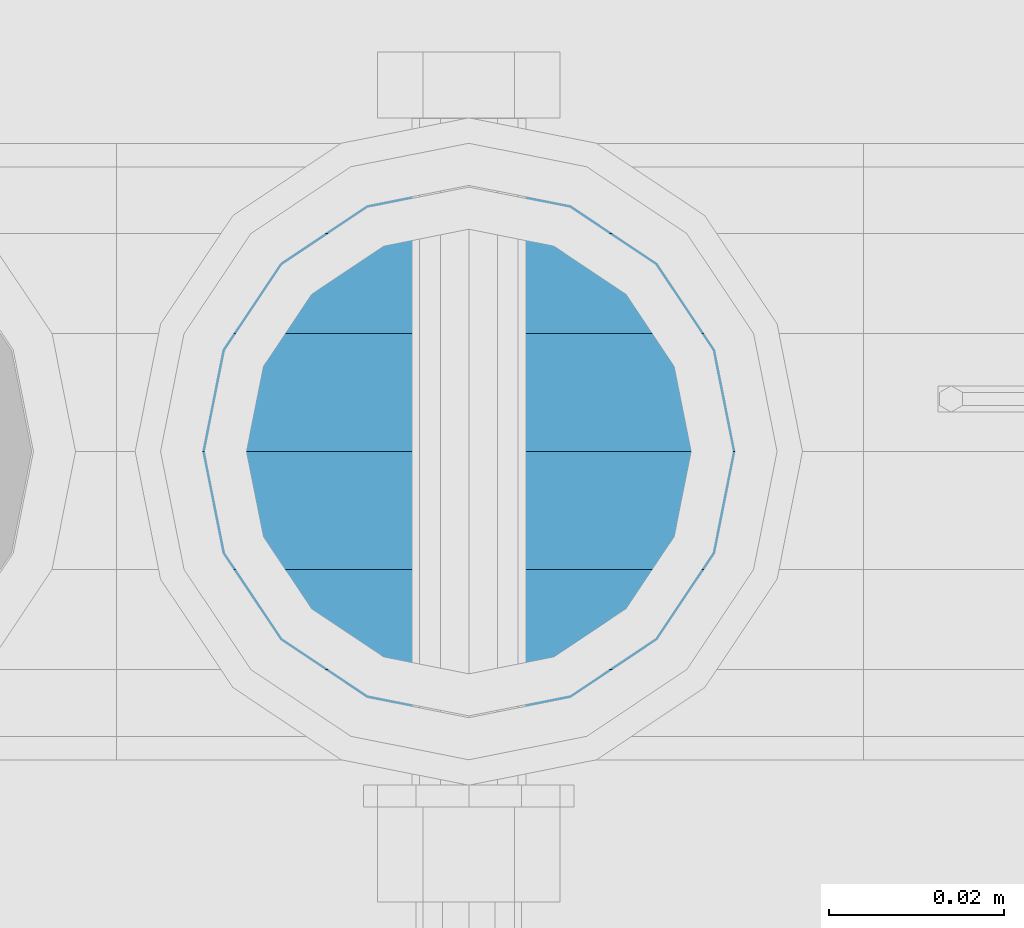
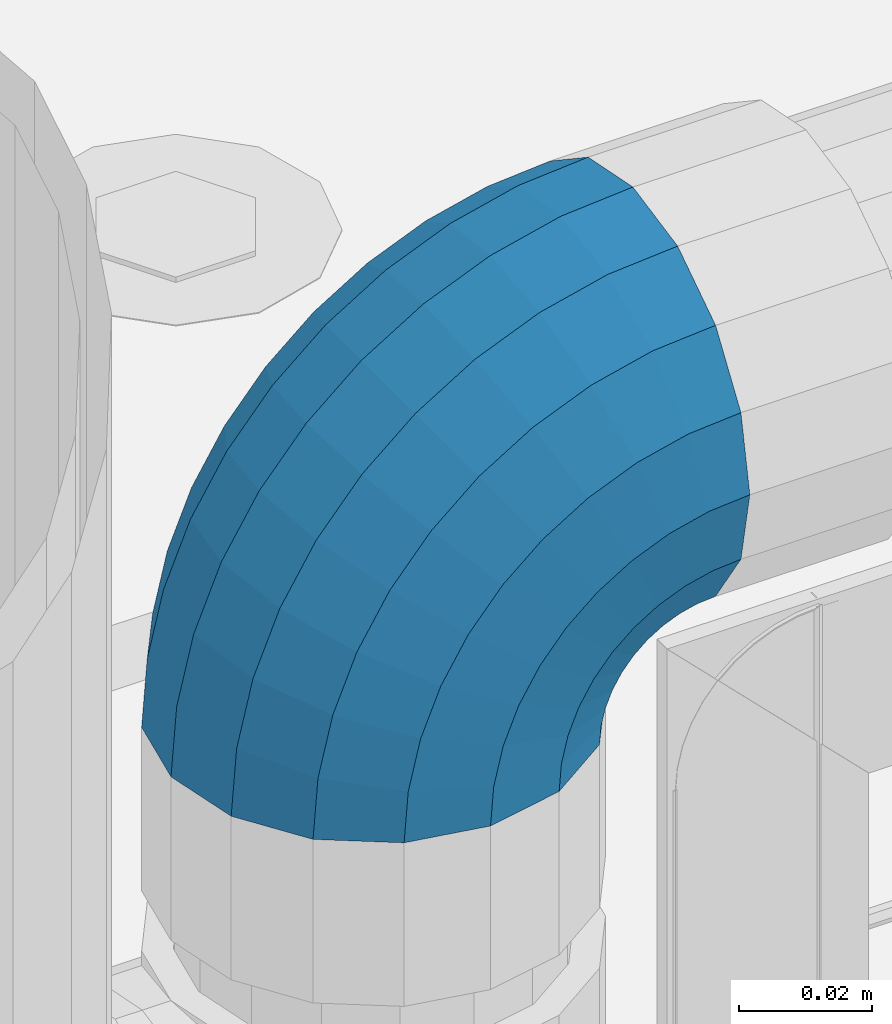
# One storey, part 147 of 240: 1 member.
"""IFC2X3 building model written with IfcOpenShell, lengths in millimetres."""

from ifc_helpers import new_model, si_unit, frame, origin_with_axes, place, context, subcontext, project, spatial, faceted_brep, material, type_object, element, save


model = new_model("IFC2X3")

# Units and contexts
model_context = context("Model", 3, precision=1e-05, world=origin_with_axes())
body_context = subcontext(model_context, "Body", "Model", "MODEL_VIEW")
ifc_project = project(units=[si_unit("LENGTHUNIT", "METRE", prefix="MILLI"), si_unit("AREAUNIT", "SQUARE_METRE"), si_unit("VOLUMEUNIT", "CUBIC_METRE"), si_unit("MASSUNIT", "GRAM", prefix="KILO"), si_unit("TIMEUNIT", "SECOND"), si_unit("PLANEANGLEUNIT", "RADIAN"), si_unit("SOLIDANGLEUNIT", "STERADIAN"), si_unit("THERMODYNAMICTEMPERATUREUNIT", "DEGREE_CELSIUS"), si_unit("LUMINOUSINTENSITYUNIT", "LUMEN")], contexts=[model_context])

# Site, building, storey
site_placement = place(None, origin_with_axes())
site = spatial("IfcSite", under=ifc_project, at=site_placement, CompositionType="ELEMENT")
building_placement = place(site_placement, origin_with_axes())
building = spatial("IfcBuilding", under=site, at=building_placement, Name="Standard", CompositionType="ELEMENT")
storey_placement = place(building_placement, origin_with_axes())
storey = spatial("IfcBuildingStorey", under=building, at=storey_placement, Name="Undefined", CompositionType="ELEMENT", Elevation=0.0)

# Member
ifc_material = material(Name="Misc_Undefined")
member_type = type_object("IfcMemberType", PredefinedType="NOTDEFINED")
member_placement = place(storey_placement, frame((43071.0, 34664.5, 924.849999999999), z_axis=(-0.707106781186548, 0.0, 0.707106781186548), x_axis=(0.707106781186541, -1.49999999888231e-07, 0.707106781186538)))
element("IfcMember", 1, at=member_placement, inside=storey, type_object=member_type, material=ifc_material, context=body_context, shape_type="Brep", body=[
    faceted_brep([(0.0, -35.1500000000015, 0.0), (9.51152146006643, -32.4743655677739, -9.51152146006643), (13.2759578763362, -32.4743655677739, -6.29638902527222), (5.36946880023606, -35.1500000000015, 4.58595959348168), (17.5749999999971, -24.8548033587067, -17.5749999999971), (19.9787556631127, -24.8548033587067, -15.5219987155579), (22.9628441077002, -13.4513226476338, -22.9628441077002), (24.4574219585265, -13.4513226476338, -21.686354032383), (24.8548033587067, 0.0, -24.8548033587067), (26.0301204183124, 0.0, -23.8509877588003), (22.9628441077002, 13.4513226476338, -22.9628441077002), (24.4574219585265, 13.4513226476338, -21.686354032383), (17.5749999999971, 24.8548033587067, -17.5749999999971), (19.9787556631127, 24.8548033587067, -15.5219987155579), (9.51152146006643, 32.4743655677739, -9.51152146006643), (13.2759578763362, 32.4743655677739, -6.29638902527222), (0.0, 35.1500000000015, 0.0), (5.36946880023606, 35.1500000000015, 4.58595959348168), (-9.51152146007371, 32.4743655677739, 9.51152146007371), (-2.53702027587133, 32.4743655677739, 15.4683082122356), (-17.5749999999971, 24.8548033587067, 17.5750000000044), (-9.23981806264055, 24.8548033587067, 24.6939179025212), (-22.9628441077075, 13.4513226476338, 22.9628441077075), (-13.7184843580544, 13.4513226476338, 30.8582732193609), (-24.8548033587067, 0.0, 24.854803358714), (-15.2911828178476, 0.0, 33.0229069457637), (-22.9628441077075, -13.4513226476338, 22.9628441077075), (-13.7184843580544, -13.4513226476338, 30.8582732193609), (-17.5749999999971, -24.8548033587067, 17.5750000000044), (-9.23981806264055, -24.8548033587067, 24.6939179025212), (-9.51152146007371, -32.4743655677739, 9.51152146007371), (-2.53702027587133, -32.4743655677739, 15.4683082122356), (0.0, -30.3499999999985, 0.0), (-8.21265081971796, -28.0397438117143, 8.21265081971796), (-1.45732902223244, -28.0397438117143, 13.9822406910389), (5.36946880023606, -30.3499999999985, 4.58595959348168), (-15.1750000000029, -21.4606908090136, 15.1750000000029), (-7.24480876131565, -21.4606908090136, 21.9480231689959), (-19.8270929919963, -11.6144421722784, 19.8270929919963), (-11.1118790903492, -11.6144421722784, 27.2705888550845), (-21.4606908090136, 0.0, 21.4606908090136), (-12.46981360684, 0.0, 29.139625372758), (-19.8270929919963, 11.6144421722784, 19.8270929919963), (-11.1118790903492, 11.6144421722784, 27.2705888550845), (-15.1750000000029, 21.4606908090136, 15.1750000000029), (-7.24480876131565, 21.4606908090136, 21.9480231689959), (-8.21265081971796, 28.0397438117143, 8.21265081971796), (-1.45732902223244, 28.0397438117143, 13.9822406910389), (0.0, 30.3499999999985, 0.0), (5.36946880023606, 30.3499999999985, 4.58595959348168), (8.21265081971796, 28.0397438117143, -8.21265081971796), (12.1962666227046, 28.0397438117143, -4.81032150407555), (15.1750000000029, 21.4606908090136, -15.1749999999956), (17.9837463617805, 21.4606908090136, -12.7761039820398), (19.8270929919963, 11.6144421722784, -19.8270929919963), (21.8508166908287, 11.6144421722784, -18.0986696681139), (21.4606908090136, 0.0, -21.4606908090063), (23.2087512073122, 0.0, -19.9677061857947), (19.8270929919963, -11.6144421722784, -19.8270929919963), (21.8508166908287, -11.6144421722784, -18.0986696681139), (15.1750000000029, -21.4606908090136, -15.1749999999956), (17.9837463617805, -21.4606908090136, -12.7761039820398), (8.21265081971796, -28.0397438117143, -8.21265081971796), (12.1962666227046, -28.0397438117143, -4.81032150407555), (17.4970053560755, -32.4743655677739, -3.70972780291777), (11.390232665115, -35.1500000000015, 8.27548843508703), (22.6740772628618, -24.8548033587067, -13.8703035149447), (26.1332861179544, -13.4513226476338, -20.6593831546707), (27.347998730962, 0.0, -23.0433908901396), (26.1332861179544, 13.4513226476338, -20.6593831546707), (22.6740772628618, 24.8548033587067, -13.8703035149447), (17.4970053560755, 32.4743655677739, -3.70972780291777), (11.390232665115, 35.1500000000015, 8.27548843508703), (5.28345997416181, 32.4743655677739, 20.2607046730918), (0.106388067375519, 24.8548033587067, 30.4212803851042), (-3.35282078771706, 13.4513226476338, 37.210360024852), (-4.56753340072464, 0.0, 39.5943677603063), (-3.35282078771706, -13.4513226476338, 37.210360024852), (0.106388067375519, -24.8548033587067, 30.4212803851042), (5.28345997416181, -32.4743655677739, 20.2607046730918), (6.11738625913131, -28.0397438117143, 18.6240321853984), (11.390232665115, -30.3499999999985, 8.27548843508703), (1.64728291997744, -21.4606908090136, 27.3971039595053), (-1.33954464053386, -11.6144421722784, 33.2590831078996), (-2.38837900197541, 0.0, 35.3175364442068), (-1.33954464053386, 11.6144421722784, 33.2590831078996), (1.64728291997744, 21.4606908090136, 27.3971039595053), (6.11738625913131, 28.0397438117143, 18.6240321853984), (11.390232665115, 30.3499999999985, 8.27548843508703), (16.663079071106, 28.0397438117143, -2.07305531522434), (21.1331824102599, 21.4606908090136, -10.8461270893313), (24.1200099707639, 11.6144421722784, -16.7081062377256), (25.1688443322128, 0.0, -18.7665595740255), (24.1200099707639, -11.6144421722784, -16.7081062377256), (21.1331824102599, -21.4606908090136, -10.8461270893313), (16.663079071106, -28.0397438117143, -2.07305531522434), (22.070727701459, -32.4743655677739, -1.81522997692809), (17.9140404065256, -35.1500000000015, 10.9777380798914), (25.5945970362081, -24.8548033587067, -12.6605846156453), (27.9491712485105, -13.4513226476338, -19.9072189058861), (28.7759877588032, 0.0, -22.4518984678798), (27.9491712485105, 13.4513226476338, -19.9072189058861), (25.5945970362081, 24.8548033587067, -12.6605846156453), (22.070727701459, 32.4743655677739, -1.81522997692809), (17.9140404065256, 35.1500000000015, 10.9777380798914), (13.7573531115777, 32.4743655677739, 23.7707061367109), (10.2334837768358, 24.8548033587067, 34.6160607754209), (7.87890956454066, 13.4513226476338, 41.862695065669), (7.05209305424796, 0.0, 44.4073746276699), (7.87890956454066, -13.4513226476338, 41.862695065669), (10.2334837768358, -24.8548033587067, 34.6160607754209), (13.7573531115777, -32.4743655677739, 23.7707061367109), (14.3249803951039, -28.0397438117143, 22.023728990971), (17.9140404065256, -30.3499999999985, 10.9777380798914), (11.2823222355146, -21.4606908090136, 31.3880679180002), (9.24928305078356, -11.6144421722784, 37.6451191472734), (8.53537462724489, 0.0, 39.8423033494473), (9.24928305078356, 11.6144421722784, 37.6451191472734), (11.2823222355146, 21.4606908090136, 31.3880679180002), (14.3249803951039, 28.0397438117143, 22.023728990971), (17.9140404065256, 30.3499999999985, 10.9777380798914), (21.5031004179473, 28.0397438117143, -0.0682528311954229), (24.5457585775293, 21.4606908090136, -9.43259175821731), (26.5787977622676, 11.6144421722784, -15.6896429874905), (27.2927061858063, 0.0, -17.8868271896717), (26.5787977622676, -11.6144421722784, -15.6896429874905), (24.5457585775293, -21.4606908090136, -9.43259175821731), (21.5031004179473, -28.0397438117143, -0.0682528311954229), (26.8845046890492, -32.4743655677739, -0.659544371257653), (24.7802542265854, -35.1500000000015, 12.6261701733893), (28.6684020936882, -24.8548033587067, -11.9226293117827), (29.860364231703, -13.4513226476338, -19.4483820661189), (30.2789256727556, 0.0, -22.0910749985269), (29.860364231703, 13.4513226476338, -19.4483820661189), (28.6684020936882, 24.8548033587067, -11.9226293117827), (26.8845046890492, 32.4743655677739, -0.659544371257653), (24.7802542265854, 35.1500000000015, 12.6261701733893), (22.6760037641216, 32.4743655677739, 25.9118847180362), (20.8921063594826, 24.8548033587067, 37.1749696585684), (19.7001442214678, 13.4513226476338, 44.7007224129047), (19.2815827804225, 0.0, 47.3434153453127), (19.7001442214678, -13.4513226476338, 44.7007224129047), (20.8921063594826, -24.8548033587067, 37.1749696585684), (22.6760037641216, -32.4743655677739, 25.9118847180362), (22.9633551786319, -28.0397438117143, 24.0976192894668), (24.7802542265854, -30.3499999999985, 12.6261701733893), (21.4230625404889, -21.4606908090136, 33.8226442665691), (20.3938719035359, -11.6144421722784, 40.3206982095071), (20.0324682126156, 0.0, 42.6025113104479), (20.3938719035359, 11.6144421722784, 40.3206982095071), (21.4230625404889, 21.4606908090136, 33.8226442665691), (22.9633551786319, 28.0397438117143, 24.0976192894668), (24.7802542265854, 30.3499999999985, 12.6261701733893), (26.5971532745461, 28.0397438117143, 1.15472105731169), (28.1374459126891, 21.4606908090136, -8.57030391978333), (29.1666365496349, 11.6144421722784, -15.0683578627213), (29.5280402405551, 0.0, -17.3501709636694), (29.1666365496349, -11.6144421722784, -15.0683578627213), (28.1374459126891, -21.4606908090136, -8.57030391978333), (26.5971532745461, -28.0397438117143, 1.15472105731169), (31.8198051533982, -32.4743655677739, -0.271127801024704), (31.8198051533909, -35.1500000000015, 13.1801948466091), (31.8198051533982, -24.8548033587067, -11.6746085120976), (31.8198051533909, -13.4513226476338, -19.2941707211648), (31.8198051533982, 0.0, -21.9698051533924), (31.8198051533909, 13.4513226476338, -19.2941707211648), (31.8198051533982, 24.8548033587067, -11.6746085120976), (31.8198051533982, 32.4743655677739, -0.271127801024704), (31.8198051533909, 35.1500000000015, 13.1801948466091), (31.8198051533982, 32.4743655677739, 26.6315174942429), (31.8198051533982, 24.8548033587067, 38.0349982053158), (31.8198051533909, 13.4513226476338, 45.654560414383), (31.8198051533982, 0.0, 48.3301948466178), (31.8198051533909, -13.4513226476338, 45.654560414383), (31.8198051533982, -24.8548033587067, 38.0349982053158), (31.8198051533982, -32.4743655677739, 26.6315174942429), (31.8198051533982, -28.0397438117143, 24.7946370188947), (31.8198051533909, -30.3499999999985, 13.1801948466091), (31.8198051533982, -21.4606908090136, 34.6408856556227), (31.8198051533982, -11.6144421722784, 41.2199386583306), (31.8198051533982, 0.0, 43.5301948466076), (31.8198051533982, 11.6144421722784, 41.2199386583306), (31.8198051533982, 21.4606908090136, 34.6408856556227), (31.8198051533982, 28.0397438117143, 24.7946370188947), (31.8198051533909, 30.3499999999985, 13.1801948466091), (31.8198051533982, 28.0397438117143, 1.56575267433072), (31.8198051533982, 21.4606908090136, -8.28049596239725), (31.8198051533982, 11.6144421722784, -14.8595489651125), (31.8198051533982, 0.0, -17.1698051533895), (31.8198051533982, -11.6144421722784, -14.8595489651125), (31.8198051533982, -21.4606908090136, -8.28049596239725), (31.8198051533982, -28.0397438117143, 1.56575267433072), (36.7551056177399, -32.4743655677739, -0.659544371264928), (38.859356080211, -35.1500000000015, 12.6261701733965), (34.9712082131082, -24.8548033587067, -11.9226293117899), (33.7792460750934, -13.4513226476338, -19.4483820661189), (33.3606846340408, 0.0, -22.0910749985342), (33.7792460750934, 13.4513226476338, -19.4483820661189), (34.9712082131082, 24.8548033587067, -11.9226293117899), (36.7551056177399, 32.4743655677739, -0.659544371264928), (38.859356080211, 35.1500000000015, 12.6261701733965), (40.9636065426675, 32.4743655677739, 25.9118847180434), (42.7475039473065, 24.8548033587067, 37.1749696585684), (43.9394660853213, 13.4513226476338, 44.7007224129047), (44.3580275263739, 0.0, 47.3434153453054), (43.9394660853213, -13.4513226476338, 44.7007224129047), (42.7475039473065, -24.8548033587067, 37.1749696585684), (40.9636065426675, -32.4743655677739, 25.9118847180434), (40.6762551281645, -28.0397438117143, 24.0976192894668), (38.859356080211, -30.3499999999985, 12.6261701733965), (42.2165477663075, -21.4606908090136, 33.8226442665691), (43.2457384032605, -11.6144421722784, 40.3206982094998), (43.6071420941807, 0.0, 42.6025113104552), (43.2457384032605, 11.6144421722784, 40.3206982094998), (42.2165477663075, 21.4606908090136, 33.8226442665691), (40.6762551281645, 28.0397438117143, 24.0976192894668), (38.859356080211, 30.3499999999985, 12.6261701733965), (37.042457032243, 28.0397438117143, 1.15472105731169), (35.5021643941072, 21.4606908090136, -8.57030391978333), (34.4729737571543, 11.6144421722784, -15.068357862714), (34.111570066234, 0.0, -17.3501709636694), (34.4729737571543, -11.6144421722784, -15.068357862714), (35.5021643941072, -21.4606908090136, -8.57030391978333), (37.042457032243, -28.0397438117143, 1.15472105731169), (41.5688826053301, -32.4743655677739, -1.81522997692809), (45.7255699002708, -35.1500000000015, 10.9777380798987), (38.0450132705882, -24.8548033587067, -12.6605846156381), (35.6904390582786, -13.4513226476338, -19.9072189058934), (34.8636225479859, 0.0, -22.4518984678871), (35.6904390582786, 13.4513226476338, -19.9072189058934), (38.0450132705882, 24.8548033587067, -12.6605846156381), (41.5688826053301, 32.4743655677739, -1.81522997692809), (45.7255699002708, 35.1500000000015, 10.9777380798987), (49.8822571952041, 32.4743655677739, 23.7707061367109), (53.4061265299533, 24.8548033587067, 34.6160607754282), (55.7607007422557, 13.4513226476338, 41.862695065669), (56.5875172525484, 0.0, 44.4073746276626), (55.7607007422557, -13.4513226476338, 41.862695065669), (53.4061265299533, -24.8548033587067, 34.6160607754282), (49.8822571952041, -32.4743655677739, 23.7707061367109), (49.3146299116925, -28.0397438117143, 22.023728990971), (45.7255699002708, -30.3499999999985, 10.9777380798987), (52.3572880712745, -21.4606908090136, 31.3880679180002), (54.3903272560128, -11.6144421722784, 37.6451191472734), (55.1042356795515, 0.0, 39.8423033494473), (54.3903272560128, 11.6144421722784, 37.6451191472734), (52.3572880712745, 21.4606908090136, 31.3880679180002), (49.3146299116925, 28.0397438117143, 22.023728990971), (45.7255699002708, 30.3499999999985, 10.9777380798987), (42.1365098888491, 28.0397438117143, -0.068252831188147), (39.0938517292598, 21.4606908090136, -9.43259175821731), (37.0608125445287, 11.6144421722784, -15.6896429874905), (36.3469041209901, 0.0, -17.8868271896645), (37.0608125445287, -11.6144421722784, -15.6896429874905), (39.0938517292598, -21.4606908090136, -9.43259175821731), (42.1365098888491, -28.0397438117143, -0.068252831188147), (46.1426049507209, -32.4743655677739, -3.70972780291777), (52.2493776416741, -35.1500000000015, 8.27548843508703), (40.9655330439346, -24.8548033587067, -13.8703035149374), (37.506324188842, -13.4513226476338, -20.6593831546707), (36.2916115758271, 0.0, -23.0433908901323), (37.506324188842, 13.4513226476338, -20.6593831546707), (40.9655330439346, 24.8548033587067, -13.8703035149374), (46.1426049507209, 32.4743655677739, -3.70972780291777), (52.2493776416741, 35.1500000000015, 8.27548843508703), (58.3561503326346, 32.4743655677739, 20.2607046730918), (63.5332222394209, 24.8548033587067, 30.4212803851115), (66.9924310945134, 13.4513226476338, 37.2103600248447), (68.207143707521, 0.0, 39.5943677603063), (66.9924310945134, -13.4513226476338, 37.2103600248447), (63.5332222394209, -24.8548033587067, 30.4212803851115), (58.3561503326346, -32.4743655677739, 20.2607046730918), (57.5222240476651, -28.0397438117143, 18.6240321853984), (52.2493776416741, -30.3499999999985, 8.27548843508703), (61.9923273868189, -21.4606908090136, 27.3971039594981), (64.979154947323, -11.6144421722784, 33.2590831078924), (66.0279893087718, 0.0, 35.3175364442068), (64.979154947323, 11.6144421722784, 33.2590831078924), (61.9923273868189, 21.4606908090136, 27.3971039594981), (57.5222240476651, 28.0397438117143, 18.6240321853984), (52.2493776416741, 30.3499999999985, 8.27548843508703), (46.9765312356903, 28.0397438117143, -2.07305531523161), (42.5064278965365, 21.4606908090136, -10.8461270893313), (39.5196003360252, 11.6144421722784, -16.7081062377256), (38.4707659745836, 0.0, -18.7665595740327), (39.5196003360252, -11.6144421722784, -16.7081062377256), (42.5064278965365, -21.4606908090136, -10.8461270893313), (46.9765312356903, -28.0397438117143, -2.07305531523161), (50.3636524304529, -32.4743655677739, -6.2963890252795), (58.2701415065603, -35.1500000000015, 4.58595959348895), (43.6608546436837, -24.8548033587067, -15.5219987155579), (39.1821883482698, -13.4513226476338, -21.6863540323902), (37.6094898884767, 0.0, -23.8509877587931), (39.1821883482698, 13.4513226476338, -21.6863540323902), (43.6608546436837, 24.8548033587067, -15.5219987155579), (50.3636524304529, 32.4743655677739, -6.2963890252795), (58.2701415065603, 35.1500000000015, 4.58595959348895), (66.1766305826604, 32.4743655677739, 15.4683082122356), (72.8794283694297, 24.8548033587067, 24.6939179025212), (77.3580946648508, 13.4513226476338, 30.8582732193536), (78.9307931246367, 0.0, 33.0229069457637), (77.3580946648508, -13.4513226476338, 30.8582732193536), (72.8794283694297, -24.8548033587067, 24.6939179025212), (66.1766305826604, -32.4743655677739, 15.4683082122356), (65.0969393290288, -28.0397438117143, 13.9822406910462), (58.2701415065603, -30.3499999999985, 4.58595959348895), (70.884419068112, -21.4606908090136, 21.9480231689959), (74.7514893971456, -11.6144421722784, 27.2705888550845), (76.1094239136364, 0.0, 29.139625372758), (74.7514893971456, 11.6144421722784, 27.2705888550845), (70.884419068112, 21.4606908090136, 21.9480231689959), (65.0969393290288, 28.0397438117143, 13.9822406910462), (58.2701415065603, 30.3499999999985, 4.58595959348895), (51.4433436840845, 28.0397438117143, -4.81032150407555), (45.6558639450086, 21.4606908090136, -12.7761039820325), (41.7887936159677, 11.6144421722784, -18.0986696681211), (40.4308590994842, 0.0, -19.9677061858019), (41.7887936159677, -11.6144421722784, -18.0986696681211), (45.6558639450086, -21.4606908090136, -12.7761039820325), (51.4433436840845, -28.0397438117143, -4.81032150407555), (54.1280888467154, -32.4743655677739, -9.51152146006643), (63.6396103067891, -35.1500000000015, 7.27595761418343e-12), (46.0646103067847, -24.8548033587067, -17.5749999999971), (40.6767661990889, -13.4513226476338, -22.9628441077002), (38.7848069480824, 0.0, -24.8548033586994), (40.6767661990889, 13.4513226476338, -22.9628441077002), (46.0646103067847, 24.8548033587067, -17.5749999999971), (54.1280888467154, 32.4743655677739, -9.51152146006643), (63.6396103067891, 35.1500000000015, 7.27595761418343e-12), (73.1511317668555, 32.4743655677739, 9.51152146007371), (81.2146103067862, 24.8548033587067, 17.5750000000044), (86.6024544144893, 13.4513226476338, 22.9628441077075), (88.4944136654958, 0.0, 24.854803358714), (86.6024544144893, -13.4513226476338, 22.9628441077075), (81.2146103067862, -24.8548033587067, 17.5750000000044), (73.1511317668555, -32.4743655677739, 9.51152146007371), (71.8522611265071, -28.0397438117143, 8.21265081972524), (63.6396103067891, -30.3499999999985, 7.27595761418343e-12), (78.8146103067847, -21.4606908090136, 15.1750000000029), (83.4667032987854, -11.6144421722784, 19.8270929920036), (85.1003011158027, 0.0, 21.4606908090136), (83.4667032987854, 11.6144421722784, 19.8270929920036), (78.8146103067847, 21.4606908090136, 15.1750000000029), (71.8522611265071, 28.0397438117143, 8.21265081972524), (63.6396103067891, 30.3499999999985, 7.27595761418343e-12), (55.4269594870711, 28.0397438117143, -8.21265081971069), (48.4646103067862, 21.4606908090136, -15.1749999999956), (43.8125173147855, 11.6144421722784, -19.8270929919963), (42.1789194977755, 0.0, -21.4606908090063), (43.8125173147855, -11.6144421722784, -19.8270929919963), (48.4646103067862, -21.4606908090136, -15.1749999999956), (55.4269594870711, -28.0397438117143, -8.21265081971069)], [[[0, 1, 2, 3]], [[1, 4, 5, 2]], [[4, 6, 7, 5]], [[6, 8, 9, 7]], [[8, 10, 11, 9]], [[10, 12, 13, 11]], [[12, 14, 15, 13]], [[14, 16, 17, 15]], [[16, 18, 19, 17]], [[18, 20, 21, 19]], [[20, 22, 23, 21]], [[22, 24, 25, 23]], [[24, 26, 27, 25]], [[26, 28, 29, 27]], [[28, 30, 31, 29]], [[30, 0, 3, 31]], [[32, 33, 34, 35]], [[33, 36, 37, 34]], [[36, 38, 39, 37]], [[38, 40, 41, 39]], [[40, 42, 43, 41]], [[42, 44, 45, 43]], [[44, 46, 47, 45]], [[46, 48, 49, 47]], [[48, 50, 51, 49]], [[50, 52, 53, 51]], [[52, 54, 55, 53]], [[54, 56, 57, 55]], [[56, 58, 59, 57]], [[58, 60, 61, 59]], [[60, 62, 63, 61]], [[62, 32, 35, 63]], [[30, 28, 26, 24, 22, 20, 18, 16, 14, 12, 10, 8, 6, 4, 1, 0], [62, 60, 58, 56, 54, 52, 50, 48, 46, 44, 42, 40, 38, 36, 33, 32]], [[3, 2, 64, 65]], [[2, 5, 66, 64]], [[5, 7, 67, 66]], [[7, 9, 68, 67]], [[9, 11, 69, 68]], [[11, 13, 70, 69]], [[13, 15, 71, 70]], [[15, 17, 72, 71]], [[17, 19, 73, 72]], [[19, 21, 74, 73]], [[21, 23, 75, 74]], [[23, 25, 76, 75]], [[25, 27, 77, 76]], [[27, 29, 78, 77]], [[29, 31, 79, 78]], [[31, 3, 65, 79]], [[35, 34, 80, 81]], [[34, 37, 82, 80]], [[37, 39, 83, 82]], [[39, 41, 84, 83]], [[41, 43, 85, 84]], [[43, 45, 86, 85]], [[45, 47, 87, 86]], [[47, 49, 88, 87]], [[49, 51, 89, 88]], [[51, 53, 90, 89]], [[53, 55, 91, 90]], [[55, 57, 92, 91]], [[57, 59, 93, 92]], [[59, 61, 94, 93]], [[61, 63, 95, 94]], [[63, 35, 81, 95]], [[65, 64, 96, 97]], [[64, 66, 98, 96]], [[66, 67, 99, 98]], [[67, 68, 100, 99]], [[68, 69, 101, 100]], [[69, 70, 102, 101]], [[70, 71, 103, 102]], [[71, 72, 104, 103]], [[72, 73, 105, 104]], [[73, 74, 106, 105]], [[74, 75, 107, 106]], [[75, 76, 108, 107]], [[76, 77, 109, 108]], [[77, 78, 110, 109]], [[78, 79, 111, 110]], [[79, 65, 97, 111]], [[81, 80, 112, 113]], [[80, 82, 114, 112]], [[82, 83, 115, 114]], [[83, 84, 116, 115]], [[84, 85, 117, 116]], [[85, 86, 118, 117]], [[86, 87, 119, 118]], [[87, 88, 120, 119]], [[88, 89, 121, 120]], [[89, 90, 122, 121]], [[90, 91, 123, 122]], [[91, 92, 124, 123]], [[92, 93, 125, 124]], [[93, 94, 126, 125]], [[94, 95, 127, 126]], [[95, 81, 113, 127]], [[97, 96, 128, 129]], [[96, 98, 130, 128]], [[98, 99, 131, 130]], [[99, 100, 132, 131]], [[100, 101, 133, 132]], [[101, 102, 134, 133]], [[102, 103, 135, 134]], [[103, 104, 136, 135]], [[104, 105, 137, 136]], [[105, 106, 138, 137]], [[106, 107, 139, 138]], [[107, 108, 140, 139]], [[108, 109, 141, 140]], [[109, 110, 142, 141]], [[110, 111, 143, 142]], [[111, 97, 129, 143]], [[113, 112, 144, 145]], [[112, 114, 146, 144]], [[114, 115, 147, 146]], [[115, 116, 148, 147]], [[116, 117, 149, 148]], [[117, 118, 150, 149]], [[118, 119, 151, 150]], [[119, 120, 152, 151]], [[120, 121, 153, 152]], [[121, 122, 154, 153]], [[122, 123, 155, 154]], [[123, 124, 156, 155]], [[124, 125, 157, 156]], [[125, 126, 158, 157]], [[126, 127, 159, 158]], [[127, 113, 145, 159]], [[129, 128, 160, 161]], [[128, 130, 162, 160]], [[130, 131, 163, 162]], [[131, 132, 164, 163]], [[132, 133, 165, 164]], [[133, 134, 166, 165]], [[134, 135, 167, 166]], [[135, 136, 168, 167]], [[136, 137, 169, 168]], [[137, 138, 170, 169]], [[138, 139, 171, 170]], [[139, 140, 172, 171]], [[140, 141, 173, 172]], [[141, 142, 174, 173]], [[142, 143, 175, 174]], [[143, 129, 161, 175]], [[145, 144, 176, 177]], [[144, 146, 178, 176]], [[146, 147, 179, 178]], [[147, 148, 180, 179]], [[148, 149, 181, 180]], [[149, 150, 182, 181]], [[150, 151, 183, 182]], [[151, 152, 184, 183]], [[152, 153, 185, 184]], [[153, 154, 186, 185]], [[154, 155, 187, 186]], [[155, 156, 188, 187]], [[156, 157, 189, 188]], [[157, 158, 190, 189]], [[158, 159, 191, 190]], [[159, 145, 177, 191]], [[161, 160, 192, 193]], [[160, 162, 194, 192]], [[162, 163, 195, 194]], [[163, 164, 196, 195]], [[164, 165, 197, 196]], [[165, 166, 198, 197]], [[166, 167, 199, 198]], [[167, 168, 200, 199]], [[168, 169, 201, 200]], [[169, 170, 202, 201]], [[170, 171, 203, 202]], [[171, 172, 204, 203]], [[172, 173, 205, 204]], [[173, 174, 206, 205]], [[174, 175, 207, 206]], [[175, 161, 193, 207]], [[177, 176, 208, 209]], [[176, 178, 210, 208]], [[178, 179, 211, 210]], [[179, 180, 212, 211]], [[180, 181, 213, 212]], [[181, 182, 214, 213]], [[182, 183, 215, 214]], [[183, 184, 216, 215]], [[184, 185, 217, 216]], [[185, 186, 218, 217]], [[186, 187, 219, 218]], [[187, 188, 220, 219]], [[188, 189, 221, 220]], [[189, 190, 222, 221]], [[190, 191, 223, 222]], [[191, 177, 209, 223]], [[193, 192, 224, 225]], [[192, 194, 226, 224]], [[194, 195, 227, 226]], [[195, 196, 228, 227]], [[196, 197, 229, 228]], [[197, 198, 230, 229]], [[198, 199, 231, 230]], [[199, 200, 232, 231]], [[200, 201, 233, 232]], [[201, 202, 234, 233]], [[202, 203, 235, 234]], [[203, 204, 236, 235]], [[204, 205, 237, 236]], [[205, 206, 238, 237]], [[206, 207, 239, 238]], [[207, 193, 225, 239]], [[209, 208, 240, 241]], [[208, 210, 242, 240]], [[210, 211, 243, 242]], [[211, 212, 244, 243]], [[212, 213, 245, 244]], [[213, 214, 246, 245]], [[214, 215, 247, 246]], [[215, 216, 248, 247]], [[216, 217, 249, 248]], [[217, 218, 250, 249]], [[218, 219, 251, 250]], [[219, 220, 252, 251]], [[220, 221, 253, 252]], [[221, 222, 254, 253]], [[222, 223, 255, 254]], [[223, 209, 241, 255]], [[225, 224, 256, 257]], [[224, 226, 258, 256]], [[226, 227, 259, 258]], [[227, 228, 260, 259]], [[228, 229, 261, 260]], [[229, 230, 262, 261]], [[230, 231, 263, 262]], [[231, 232, 264, 263]], [[232, 233, 265, 264]], [[233, 234, 266, 265]], [[234, 235, 267, 266]], [[235, 236, 268, 267]], [[236, 237, 269, 268]], [[237, 238, 270, 269]], [[238, 239, 271, 270]], [[239, 225, 257, 271]], [[241, 240, 272, 273]], [[240, 242, 274, 272]], [[242, 243, 275, 274]], [[243, 244, 276, 275]], [[244, 245, 277, 276]], [[245, 246, 278, 277]], [[246, 247, 279, 278]], [[247, 248, 280, 279]], [[248, 249, 281, 280]], [[249, 250, 282, 281]], [[250, 251, 283, 282]], [[251, 252, 284, 283]], [[252, 253, 285, 284]], [[253, 254, 286, 285]], [[254, 255, 287, 286]], [[255, 241, 273, 287]], [[257, 256, 288, 289]], [[256, 258, 290, 288]], [[258, 259, 291, 290]], [[259, 260, 292, 291]], [[260, 261, 293, 292]], [[261, 262, 294, 293]], [[262, 263, 295, 294]], [[263, 264, 296, 295]], [[264, 265, 297, 296]], [[265, 266, 298, 297]], [[266, 267, 299, 298]], [[267, 268, 300, 299]], [[268, 269, 301, 300]], [[269, 270, 302, 301]], [[270, 271, 303, 302]], [[271, 257, 289, 303]], [[273, 272, 304, 305]], [[272, 274, 306, 304]], [[274, 275, 307, 306]], [[275, 276, 308, 307]], [[276, 277, 309, 308]], [[277, 278, 310, 309]], [[278, 279, 311, 310]], [[279, 280, 312, 311]], [[280, 281, 313, 312]], [[281, 282, 314, 313]], [[282, 283, 315, 314]], [[283, 284, 316, 315]], [[284, 285, 317, 316]], [[285, 286, 318, 317]], [[286, 287, 319, 318]], [[287, 273, 305, 319]], [[289, 288, 320, 321]], [[288, 290, 322, 320]], [[290, 291, 323, 322]], [[291, 292, 324, 323]], [[292, 293, 325, 324]], [[293, 294, 326, 325]], [[294, 295, 327, 326]], [[295, 296, 328, 327]], [[296, 297, 329, 328]], [[297, 298, 330, 329]], [[298, 299, 331, 330]], [[299, 300, 332, 331]], [[300, 301, 333, 332]], [[301, 302, 334, 333]], [[302, 303, 335, 334]], [[303, 289, 321, 335]], [[305, 304, 336, 337]], [[304, 306, 338, 336]], [[306, 307, 339, 338]], [[307, 308, 340, 339]], [[308, 309, 341, 340]], [[309, 310, 342, 341]], [[310, 311, 343, 342]], [[311, 312, 344, 343]], [[312, 313, 345, 344]], [[313, 314, 346, 345]], [[314, 315, 347, 346]], [[315, 316, 348, 347]], [[316, 317, 349, 348]], [[317, 318, 350, 349]], [[318, 319, 351, 350]], [[319, 305, 337, 351]], [[322, 323, 324, 325, 326, 327, 328, 329, 330, 331, 332, 333, 334, 335, 321, 320], [338, 339, 340, 341, 342, 343, 344, 345, 346, 347, 348, 349, 350, 351, 337, 336]]]),
])

save(model, "model.ifc")
